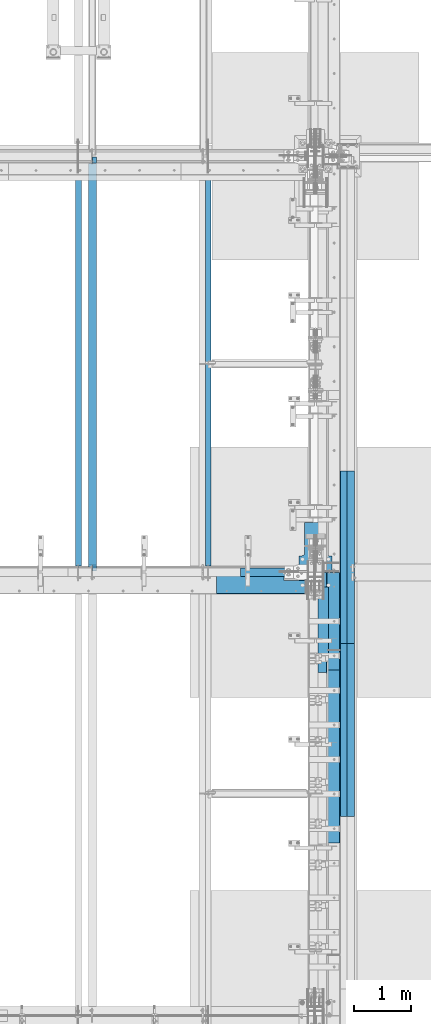
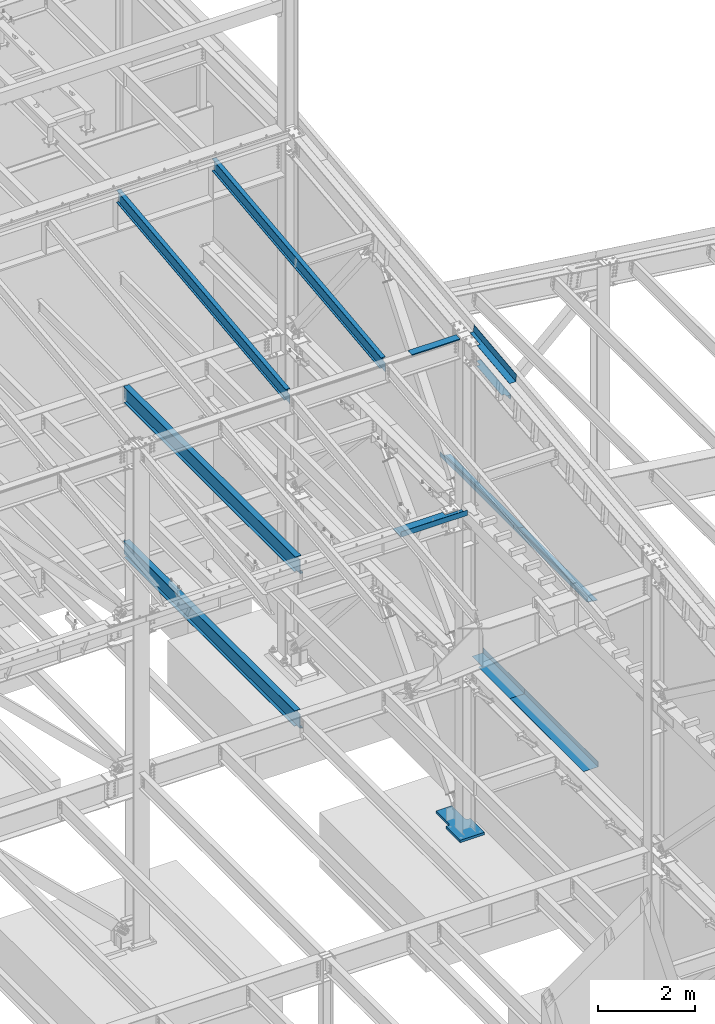
# One storey, part 740 of 1179: 15 beams, 13 elements without a shape of their own.
"""IFC2X3 building model written with IfcOpenShell, lengths in millimetres."""

import ifcopenshell
import ifcopenshell.guid

model = None  # the IFC model being written
_history = None  # IfcOwnerHistory: only IFC2X3 demands one
_inside = {}  # id of a spatial element -> (the spatial element, [elements in it])
_under = {}  # id of a project, library or spatial element -> (it, [spatial elements below it])
_declared = {}  # id of a project -> (the project, [libraries it declares])
_typed = {}  # id of a type object -> (the type object, [elements of that type])
_made_of = {}  # id of a material, layer set ... -> (it, [elements and type objects made of it])


def new_model(schema):
    """Start an empty IFC model of exactly this schema.

    Asked for "IFC4X3", IfcOpenShell would pick the latest addendum, in which some entities
    have other attributes; the version numbers below select the first issue.
    IFC2X3 requires an IfcOwnerHistory on every rooted entity: one is made here for all.
    """
    global model, _history
    if schema == "IFC4X3":
        model = ifcopenshell.file(schema_version=(4, 3, 0, 0))
    else:
        model = ifcopenshell.file(schema=schema)
    _inside.clear()
    _under.clear()
    _declared.clear()
    _typed.clear()
    _made_of.clear()
    _history = None
    if model.schema == "IFC2X3":
        org = make("IfcOrganization", Name="unknown")
        user = make(
            "IfcPersonAndOrganization",
            ThePerson=make("IfcPerson", FamilyName="unknown"),
            TheOrganization=org,
        )
        app = make(
            "IfcApplication",
            ApplicationDeveloper=org,
            Version="unknown",
            ApplicationFullName="unknown",
            ApplicationIdentifier="unknown",
        )
        _history = make(
            "IfcOwnerHistory",
            OwningUser=user,
            OwningApplication=app,
            ChangeAction="ADDED",
            CreationDate=0,
        )
    return model


def make(cls, **values):
    """One entity of the class cls with the attributes given. An attribute that is None is left unset."""
    return model.create_entity(
        cls, **{name: value for name, value in values.items() if value is not None}
    )


def rooted(cls, **values):
    """An entity with a GlobalId (a new one), such as an element, a storey or a relation."""
    return make(cls, GlobalId=ifcopenshell.guid.new(), OwnerHistory=_history, **values)


def si_unit(unit_type, name, prefix=None):
    """IfcSIUnit, for example si_unit("LENGTHUNIT", "METRE", prefix="MILLI")."""
    return make("IfcSIUnit", UnitType=unit_type, Prefix=prefix, Name=name)


def assignment(units):
    """IfcUnitAssignment: the units of a project."""
    return None if units is None else make("IfcUnitAssignment", Units=units)


def point(xyz):
    """IfcCartesianPoint."""
    return None if xyz is None else make("IfcCartesianPoint", Coordinates=xyz)


def direction(xyz):
    """IfcDirection."""
    return None if xyz is None else make("IfcDirection", DirectionRatios=xyz)


def frame(location, z_axis=None, x_axis=None):
    """IfcAxis2Placement3D, a coordinate frame: its origin and axes. An axis left out is left unset."""
    return make(
        "IfcAxis2Placement3D",
        Location=point(location),
        Axis=direction(z_axis),
        RefDirection=direction(x_axis),
    )


def origin_with_axes():
    """The frame at (0, 0, 0) with the z axis (0, 0, 1) and the x axis (1, 0, 0) written out."""
    return frame((0.0, 0.0, 0.0), z_axis=(0.0, 0.0, 1.0), x_axis=(1.0, 0.0, 0.0))


def place(relative_to, where):
    """IfcLocalPlacement: puts the frame where relative to a parent placement (None: the world)."""
    return make(
        "IfcLocalPlacement", PlacementRelTo=relative_to, RelativePlacement=where
    )


def context(
    kind, dimensions, precision=None, world=None, true_north=None, identifier=None
):
    """IfcGeometricRepresentationContext, for example the 3D "Model" context."""
    return make(
        "IfcGeometricRepresentationContext",
        ContextIdentifier=identifier,
        ContextType=kind,
        CoordinateSpaceDimension=dimensions,
        Precision=precision,
        WorldCoordinateSystem=world,
        TrueNorth=true_north,
    )


def subcontext(parent, identifier, kind, view, scale=None):
    """IfcGeometricRepresentationSubContext, for example "Body" below "Model"."""
    return make(
        "IfcGeometricRepresentationSubContext",
        ContextIdentifier=identifier,
        ContextType=kind,
        ParentContext=parent,
        TargetScale=scale,
        TargetView=view,
    )


def project(units=None, contexts=None):
    """IfcProject with its units and contexts."""
    return rooted(
        "IfcProject",
        Name="project",
        RepresentationContexts=contexts,
        UnitsInContext=assignment(units),
    )


def spatial(cls, under=None, at=None, **own):
    """A site, building, storey or space (cls), placed at a placement, below another one or the project."""
    s = rooted(cls, ObjectPlacement=at, **own)
    if under is not None:
        _under.setdefault(under.id(), (under, []))[1].append(s)
    return s


def faces_of(points, faces, orient=None, outer=None):
    """IfcFace entities. A face is a list of loops; a loop is a list of indices into points, from 0.

    orient and outer hold one flag for each loop. By default every Orientation is true, the
    first loop of a face is its IfcFaceOuterBound and the others are IfcFaceBound.
    """
    made = []
    for i, loops in enumerate(faces):
        bounds = []
        for j, loop in enumerate(loops):
            is_outer = j == 0 if outer is None else outer[i][j]
            bounds.append(
                make(
                    "IfcFaceOuterBound" if is_outer else "IfcFaceBound",
                    Bound=make("IfcPolyLoop", Polygon=[points[k] for k in loop]),
                    Orientation=True if orient is None else orient[i][j],
                )
            )
        made.append(make("IfcFace", Bounds=bounds))
    return made


def faceted_brep(points, faces, orient=None, outer=None, voids=None):
    """IfcFacetedBrep: a solid bounded by flat faces; with voids (closed shells), ...WithVoids."""
    shared = [point(p) for p in points]
    hull = make("IfcClosedShell", CfsFaces=faces_of(shared, faces, orient, outer))
    if voids is None:
        return make("IfcFacetedBrep", Outer=hull)
    return make(
        "IfcFacetedBrepWithVoids",
        Outer=hull,
        Voids=[
            make(cls, CfsFaces=faces_of(shared, fs, o, b)) for cls, fs, o, b in voids
        ],
    )


def shape(context_of_items, identifier, shape_type, items):
    """IfcShapeRepresentation: the items that make up one representation, for example the "Body"."""
    return make(
        "IfcShapeRepresentation",
        ContextOfItems=context_of_items,
        RepresentationIdentifier=identifier,
        RepresentationType=shape_type,
        Items=items,
    )


def material(Name=None, Category=None):
    """IfcMaterial."""
    return make("IfcMaterial", Name=Name, Category=Category)


def made_of(thing, what):
    """Note that an element or type object is made of a material, layer set ...; save() writes the relation."""
    if what is not None:
        _made_of.setdefault(what.id(), (what, []))[1].append(thing)
    return thing


def type_object(cls, material=None, **own):
    """A type object (cls), such as IfcWallType, which elements share."""
    return made_of(rooted(cls, **own), material)


def element(
    cls,
    number,
    at=None,
    inside=None,
    cuts=None,
    type_object=None,
    material=None,
    context=None,
    identifier="Body",
    shape_type=None,
    held_by="IfcProductDefinitionShape",
    body=None,
    shapes=None,
    **own,
):
    """One element of the class cls, such as IfcWall. Its Tag is "e" and its number.

    at: its placement. inside: the storey or other place that contains it. cuts: it is an
    opening in that element (IfcRelVoidsElement). A single representation is given by context,
    identifier, shape_type and body (its items); several are given by shapes. held_by: the class
    of the entity that holds the representations. save() writes the other relations.
    """
    e = rooted(cls, Tag="e%d" % number, ObjectPlacement=at, **own)
    if body is not None:
        shapes = [shape(context, identifier, shape_type, body)]
    if shapes is not None:
        e.Representation = make(held_by, Representations=shapes)
    if inside is not None:
        _inside.setdefault(inside.id(), (inside, []))[1].append(e)
    if cuts is not None:
        rooted(
            "IfcRelVoidsElement", RelatingBuildingElement=cuts, RelatedOpeningElement=e
        )
    if type_object is not None:
        _typed.setdefault(type_object.id(), (type_object, []))[1].append(e)
    return made_of(e, material)


def aggregate(whole, parts):
    """IfcRelAggregates: a whole, such as a stair, and the parts it consists of."""
    return rooted("IfcRelAggregates", RelatingObject=whole, RelatedObjects=parts)


def save(model, path):
    """Write the relations noted so far, then the file.

    IfcRelAggregates (storeys below a building ...), IfcRelContainedInSpatialStructure (elements
    in a storey), IfcRelDefinesByType, IfcRelAssociatesMaterial and IfcRelDeclares: one each for
    every whole, place, type object, material and project.
    """
    for whole, parts in _under.values():
        aggregate(whole, parts)
    for where, things in _inside.values():
        rooted(
            "IfcRelContainedInSpatialStructure",
            RelatedElements=things,
            RelatingStructure=where,
        )
    for kind, things in _typed.values():
        rooted("IfcRelDefinesByType", RelatedObjects=things, RelatingType=kind)
    for what, things in _made_of.values():
        rooted("IfcRelAssociatesMaterial", RelatedObjects=things, RelatingMaterial=what)
    for by, libraries in _declared.values():
        rooted("IfcRelDeclares", RelatingContext=by, RelatedDefinitions=libraries)
    model.write(path)


model = new_model("IFC2X3")

# Units and contexts
model_context = context("Model", 3, precision=1e-05, world=origin_with_axes())
body_context = subcontext(model_context, "Body", "Model", "MODEL_VIEW")
ifc_project = project(units=[si_unit("LENGTHUNIT", "METRE", prefix="MILLI"), si_unit("AREAUNIT", "SQUARE_METRE"), si_unit("VOLUMEUNIT", "CUBIC_METRE"), si_unit("MASSUNIT", "GRAM", prefix="KILO"), si_unit("TIMEUNIT", "SECOND"), si_unit("PLANEANGLEUNIT", "RADIAN"), si_unit("SOLIDANGLEUNIT", "STERADIAN"), si_unit("THERMODYNAMICTEMPERATUREUNIT", "DEGREE_CELSIUS"), si_unit("LUMINOUSINTENSITYUNIT", "LUMEN")], contexts=[model_context])

# Site, building, storey
site_placement = place(None, origin_with_axes())
site = spatial("IfcSite", under=ifc_project, at=site_placement, CompositionType="ELEMENT")
building_placement = place(site_placement, origin_with_axes())
building = spatial("IfcBuilding", under=site, at=building_placement, Name="Undefined", CompositionType="ELEMENT")
storey_placement = place(building_placement, origin_with_axes())
storey = spatial("IfcBuildingStorey", under=building, at=storey_placement, Name="Undefined", CompositionType="ELEMENT", Elevation=0.0)

# Assembly, beam
assembly_1_placement = place(storey_placement, origin_with_axes())
assembly_1 = element("IfcElementAssembly", 1, at=assembly_1_placement, inside=storey, Name="BEAM", AssemblyPlace="NOTDEFINED", PredefinedType="RIGID_FRAME")
ifc_material_1 = material(Name="STEEL/A36")
beam_type_1 = type_object("IfcBeamType", PredefinedType="NOTDEFINED")
beam_1_placement = place(assembly_1_placement, frame((23562.4690078236, 27124.0249999698, 12269.3906250184), z_axis=(-1.0, 0.0, 0.0), x_axis=(0.0, 0.0, 1.0)))
beam_1 = element("IfcBeam", 2, at=beam_1_placement, type_object=beam_type_1, material=ifc_material_1, Name="BENT_PLATE", context=body_context, shape_type="Brep", body=[
    faceted_brep([(-2.91038304567337e-11, -4.76250000000073, -575.469), (-2.91038304567337e-11, -4.76250000000073, 575.469), (2.91038304567337e-11, 4.76250000000073, 575.469), (2.91038304567337e-11, 4.76250000000073, -575.469), (43.0065173000457, 4.76249999974607, 575.469), (43.0065173000457, 4.76249999974607, -575.469), (32.3445868573126, -4.7625000001899, -575.469), (32.3445868573126, -4.7625000001899, 575.469), (25.4267481928364, -150.812499999749, 575.469), (25.4267481928364, -150.812499999749, -575.469), (16.9174425387409, -141.287499999748, -575.469), (16.9174425387409, -141.287499999748, 575.469), (2.84453562926501e-08, -150.812499999749, 575.469), (2.84453562926501e-08, -150.812499999749, -575.469), (2.84453562926501e-08, -141.287499999748, 575.469), (2.84453562926501e-08, -141.287499999748, -575.469)], [[[0, 1, 2, 3]], [[3, 2, 4, 5]], [[1, 0, 6, 7]], [[5, 4, 8, 9]], [[7, 6, 10, 11]], [[9, 8, 12, 13]], [[8, 4, 2, 1, 7, 11, 14, 12]], [[11, 10, 15, 14]], [[10, 6, 0, 3, 5, 9, 13, 15]], [[14, 15, 13, 12]]]),
])
aggregate(assembly_1, [beam_1])

assembly_2_placement = place(storey_placement, origin_with_axes())
assembly_2 = element("IfcElementAssembly", 3, at=assembly_2_placement, inside=storey, Name="BEAM", AssemblyPlace="NOTDEFINED", PredefinedType="RIGID_FRAME")
ifc_material_2 = material(Name="STEEL/A992")
beam_type_2 = type_object("IfcBeamType", Name="W16X31", PredefinedType="NOTDEFINED")
beam_2_placement = place(assembly_2_placement, frame((20370.8, 27051.0, 7812.0875), z_axis=(0.0, 0.0, 1.0), x_axis=(0.0, 1.0, 0.0)))
beam_2 = element("IfcBeam", 4, at=beam_2_placement, type_object=beam_type_2, material=ifc_material_2, Name="BEAM", ObjectType="W16X31", context=body_context, shape_type="Brep", body=[
    faceted_brep([(82.5499999999993, -3.17500000000291, 166.6875), (82.5499999999993, 3.17500000000291, 166.6875), (17.4624999999942, 3.17499999999927, 166.6875), (17.4624999999942, -3.17499999999927, 166.6875), (87.4100797087813, -3.17499999999927, 167.654229922588), (87.4100797087813, 3.17497144083973, 167.654229922588), (91.5302561769349, -3.17499999999927, 170.407243823066), (91.5302561769349, 3.17496966460385, 170.407243823066), (94.2832700774125, -3.17499999999927, 174.52742029122), (94.2832700774125, 3.1749670062818, 174.52742029122), (95.25, -3.17499999999927, 179.387499809265), (95.25, 3.1749638705769, 179.387499809265), (95.25, -69.8499999999985, 201.6125), (95.25, 69.8499999999985, 201.6125), (95.25, 69.8499999999985, 190.5), (95.25, 3.17499999999927, 190.5), (95.25, -3.17499999999927, 190.5), (95.25, -69.8499999999985, 190.5), (7196.1375, 3.17499999999927, -190.5), (7196.1375, 69.8500000000004, -190.5), (144.462499999994, 69.8499999999985, -190.5), (144.462499999994, 3.17549991607666, -190.5), (17.4624999999942, -3.17499999999927, -190.5), (17.4624999999942, -69.8499999999985, -190.5), (7323.1375, -69.8500000000004, -190.5), (7323.1375, -3.17499999999927, -190.5), (17.4624999999942, -69.8499999999985, -201.6125), (7323.1375, -69.8500000000004, -201.6125), (7196.1375, 69.8500000000004, -201.6125), (7196.1375, 3.17549991607484, -201.6125), (7323.1375, 3.17549991607484, -201.6125), (17.4624999999942, 3.17549991607666, -201.6125), (144.462499999994, 3.17549991607666, -201.6125), (144.462499999994, 69.8499999999985, -201.6125), (17.4624999999942, 3.17499999999927, -190.5), (7323.1375, 3.17499999999927, -190.5), (7323.1375, 3.17499999999927, 166.6875), (7323.1375, -3.17499999999927, 166.6875), (7235.82499980928, 3.17499999999927, 166.6875), (7235.82499980928, -3.17499999999927, 166.6875), (7230.96492029123, 3.17499999999927, 167.654229922588), (7230.96492029123, -3.17499999999927, 167.654229922588), (7226.84474382308, 3.17499999999927, 170.407243823066), (7226.84474382308, -3.17499999999927, 170.407243823066), (7224.0917299226, 3.17499999999927, 174.52742029122), (7224.0917299226, -3.17499999999927, 174.52742029122), (7223.12500000001, 3.17499999999927, 179.387499809265), (7223.12500000001, -3.17499999999927, 179.387499809265), (7223.12500000001, -69.8500000000004, 201.6125), (7223.12500000001, -69.8500000000004, 190.5), (7223.12500000001, -3.17499999999927, 190.5), (7223.12500000001, 3.17499999999927, 190.5), (7223.12500000001, 69.8500000000004, 190.5), (7223.12500000001, 69.8500000000004, 201.6125)], [[[0, 1, 2, 3]], [[4, 5, 1, 0]], [[6, 7, 5, 4]], [[8, 9, 7, 6]], [[10, 11, 9, 8]], [[12, 13, 14, 15, 11, 10, 16, 17]], [[18, 19, 20, 21]], [[22, 23, 24, 25]], [[23, 26, 27, 24]], [[28, 29, 30, 27, 26, 31, 32, 33]], [[21, 32, 31, 34]], [[20, 33, 32, 21]], [[19, 28, 33, 20]], [[18, 29, 28, 19]], [[35, 30, 29, 18]], [[25, 24, 27, 30, 35, 36, 37]], [[37, 36, 38, 39]], [[39, 38, 40, 41]], [[41, 40, 42, 43]], [[43, 42, 44, 45]], [[45, 44, 46, 47]], [[48, 49, 50, 47, 46, 51, 52, 53]], [[49, 48, 12, 17]], [[50, 49, 17, 16]], [[8, 6, 4, 0, 3, 22, 25, 37, 39, 41, 43, 45, 47, 50, 16, 10]], [[34, 31, 26, 23, 22, 3, 2]], [[51, 46, 44, 42, 40, 38, 36, 35, 18, 21, 34, 2, 1, 5, 7, 9, 11, 15]], [[52, 51, 15, 14]], [[53, 52, 14, 13]], [[48, 53, 13, 12]]]),
])
aggregate(assembly_2, [beam_2])

assembly_3_placement = place(storey_placement, origin_with_axes())
assembly_3 = element("IfcElementAssembly", 5, at=assembly_3_placement, inside=storey, Name="BEAM", AssemblyPlace="NOTDEFINED", PredefinedType="RIGID_FRAME")
beam_3_placement = place(assembly_3_placement, frame((20370.8, 27051.0, 3900.4875), z_axis=(0.0, 0.0, 1.0), x_axis=(0.0, 1.0, 0.0)))
beam_3 = element("IfcBeam", 6, at=beam_3_placement, type_object=beam_type_2, material=ifc_material_2, Name="BEAM", ObjectType="W16X31", context=body_context, shape_type="Brep", body=[
    faceted_brep([(114.300000190742, -3.17499999999927, 169.8625), (114.300000190742, 3.17497080806788, 169.8625), (19.0500000762049, 3.17499999999382, 169.8625), (19.0499999238054, -3.17500000000564, 169.8625), (119.160079708789, -3.17499999999927, 170.829229922588), (119.160079708789, 3.17497018437643, 170.829229922588), (123.280256176942, -3.17499999999927, 173.582243823066), (123.280256176942, 3.1749684082497, 173.582243823066), (126.03327007742, -3.17499999999927, 177.70242029122), (126.03327007742, 3.17496575008772, 177.70242029122), (127.000000000007, -3.17499999999927, 182.562499809265), (127.000000000007, 3.174962614572, 182.562499809265), (127.000000000007, -69.8499999999985, 201.6125), (127.000000000007, 69.8499999999985, 201.6125), (127.000000000007, 69.8499999999985, 190.5), (127.000000000007, 3.17499999999927, 190.5), (127.000000000007, -3.17499999999927, 190.5), (127.000000000007, -69.8499999999985, 190.5), (7195.34375, 3.17499999999927, -190.5), (7195.34375, 69.8499999999985, -190.5), (146.049999999996, 69.8499999999985, -190.5), (146.049999999996, 3.17549991607666, -190.5), (19.0499999999993, -3.17499999999927, -190.5), (19.0499999999993, -69.8499999999985, -190.5), (7322.34375, -69.8499999999985, -190.5), (7322.34375, -3.17499999999927, -190.5), (19.0499999999993, -69.8499999999985, -201.6125), (7322.34375, -69.8499999999985, -201.6125), (7195.34375, 69.8499999999985, -201.6125), (7195.34375, 3.17549991607666, -201.6125), (7322.34375, 3.17549991607666, -201.6125), (19.0499999999993, 3.17549991607666, -201.6125), (146.049999999996, 3.17549991607666, -201.6125), (146.049999999996, 69.8499999999985, -201.6125), (19.0499999999993, 3.17499999999927, -190.5), (7322.34375, 3.17499999999927, -190.5), (7322.34375, 3.17499999999927, 169.8625), (7322.34375, -3.17499999999927, 169.8625), (7227.09374980925, 3.17499999999927, 169.8625), (7227.09374980925, -3.17499999999927, 169.8625), (7222.2336702912, 3.17499999999927, 170.829229922588), (7222.2336702912, -3.17499999999927, 170.829229922588), (7218.11349382305, 3.17499999999927, 173.582243823066), (7218.11349382305, -3.17499999999927, 173.582243823066), (7215.36047992257, 3.17499999999927, 177.70242029122), (7215.36047992257, -3.17499999999927, 177.70242029122), (7214.39374999998, 3.17499999999927, 182.562499809265), (7214.39374999998, -3.17499999999927, 182.562499809265), (7214.39374999998, -69.8499999999985, 201.6125), (7214.39374999998, -69.8499999999985, 190.5), (7214.39374999998, -3.17499999999927, 190.5), (7214.39374999998, 3.17499999999927, 190.5), (7214.39374999998, 69.8499999999985, 190.5), (7214.39374999998, 69.8499999999985, 201.6125)], [[[0, 1, 2, 3]], [[4, 5, 1, 0]], [[6, 7, 5, 4]], [[8, 9, 7, 6]], [[10, 11, 9, 8]], [[12, 13, 14, 15, 11, 10, 16, 17]], [[18, 19, 20, 21]], [[22, 23, 24, 25]], [[23, 26, 27, 24]], [[28, 29, 30, 27, 26, 31, 32, 33]], [[21, 32, 31, 34]], [[20, 33, 32, 21]], [[19, 28, 33, 20]], [[18, 29, 28, 19]], [[35, 30, 29, 18]], [[25, 24, 27, 30, 35, 36, 37]], [[37, 36, 38, 39]], [[39, 38, 40, 41]], [[41, 40, 42, 43]], [[43, 42, 44, 45]], [[45, 44, 46, 47]], [[48, 49, 50, 47, 46, 51, 52, 53]], [[49, 48, 12, 17]], [[50, 49, 17, 16]], [[8, 6, 4, 0, 3, 22, 25, 37, 39, 41, 43, 45, 47, 50, 16, 10]], [[34, 31, 26, 23, 22, 3, 2]], [[51, 46, 44, 42, 40, 38, 36, 35, 18, 21, 34, 2, 1, 5, 7, 9, 11, 15]], [[52, 51, 15, 14]], [[53, 52, 14, 13]], [[48, 53, 13, 12]]]),
])
aggregate(assembly_3, [beam_3])

assembly_4_placement = place(storey_placement, origin_with_axes())
assembly_4 = element("IfcElementAssembly", 7, at=assembly_4_placement, inside=storey, Name="BEAM", AssemblyPlace="NOTDEFINED", PredefinedType="RIGID_FRAME")
beam_type_3 = type_object("IfcBeamType", PredefinedType="NOTDEFINED")
beam_4_placement = place(assembly_4_placement, frame((24350.6630000267, 26167.3979850945, 12206.9566078406), z_axis=(0.0, -0.993676146336441, -0.112284087038017), x_axis=(1.0, 0.0, 0.0)))
beam_4 = element("IfcBeam", 8, at=beam_4_placement, type_object=beam_type_3, material=ifc_material_1, Name="BENT_PLATE", context=body_context, shape_type="Brep", body=[
    faceted_brep([(71.4348426932302, -3.25796043364244, -469.707289102356), (71.4348773263773, 3.1749999998101, -469.707292572679), (71.4353513674432, 3.17499999964093, -885.031499999506), (71.4353167336194, -3.17500000035579, -885.031499999506), (3.63797880709171e-12, -3.17500000018845, -469.707274688342), (3.63797880709171e-12, 3.17499999980828, -469.707278158454), (153.986999996607, 3.17500000035761, 885.031499999499), (0.0, 3.17499999963911, 885.031499999503), (0.0, -3.17500000035761, 885.031499999495), (160.336999996605, -3.17499999963911, 885.031499999503), (160.336999996623, 187.324999996392, 885.031499999426), (153.986999996625, 187.324999996392, 885.031499999426), (153.986999996643, 3.17499999964093, -885.031499999506), (153.986999996625, 187.324999995672, -885.031499999579), (160.336999996623, 187.324999995672, -885.031499999579), (160.336999996642, -3.17500000035579, -885.031499999506)], [[[0, 1, 2, 3]], [[4, 5, 1, 0]], [[6, 7, 8, 9, 10, 11]], [[12, 6, 11, 13]], [[10, 14, 13, 11]], [[9, 15, 14, 10]], [[12, 13, 14, 15, 3, 2]], [[7, 6, 12, 2, 1, 5]], [[8, 7, 5, 4]], [[15, 9, 8, 4, 0, 3]]]),
])

assembly_5_placement = place(storey_placement, origin_with_axes())
assembly_5 = element("IfcElementAssembly", 9, at=assembly_5_placement, inside=storey, Name="BEAM", AssemblyPlace="NOTDEFINED", PredefinedType="RIGID_FRAME")
beam_type_4 = type_object("IfcBeamType", PredefinedType="NOTDEFINED")
beam_5_placement = place(assembly_5_placement, frame((23351.3315, 26673.175, 8147.05000610352), z_axis=(1.0, 0.0, 0.0), x_axis=(0.0, 0.0, -1.0)))
beam_5 = element("IfcBeam", 10, at=beam_5_placement, type_object=beam_type_4, material=ifc_material_1, Name="BENT_PLATE", context=body_context, shape_type="Brep", body=[
    faceted_brep([(133.350006103517, 346.074999237058, 399.256000924448), (127.000006103516, 346.074999237058, 399.256000924448), (127.000006103516, 234.950009844619, 399.256000935529), (133.350006103517, 234.950009844619, 399.256000935529), (133.350006103517, 234.950012207035, 792.956500011082), (127.000006103516, 234.950012207035, 792.9565), (0.0, -3.17499999999927, -792.9565), (0.0, -3.17499999999927, 792.9565), (0.0, 3.17499999999927, 792.9565), (0.0, 3.17499999999927, -792.9565), (127.000006103516, 3.17499999999927, 792.9565), (127.000006103516, 3.17499999999927, -792.9565), (133.350006103517, -3.17499999999927, -792.9565), (127.000006103516, 346.074999237058, -792.9565), (133.350006103517, 346.074999237058, -792.9565), (133.350006103517, -3.17499999999927, 792.9565)], [[[0, 1, 2, 3]], [[4, 3, 2, 5]], [[6, 7, 8, 9]], [[9, 8, 10, 11]], [[12, 6, 9, 11, 13, 14]], [[7, 6, 12, 15]], [[10, 8, 7, 15, 4, 5]], [[1, 13, 11, 10, 5, 2]], [[14, 13, 1, 0]], [[15, 12, 14, 0, 3, 4]]]),
])
aggregate(assembly_5, [beam_5])

# Beam
beam_type_5 = type_object("IfcBeamType", PredefinedType="NOTDEFINED")
beam_6_placement = place(assembly_4_placement, frame((24350.6629999506, 26169.0533384615, 11678.3376825604), z_axis=(0.0, -0.993676146336441, -0.112284087038017), x_axis=(1.0, 0.0, 0.0)))
beam_6 = element("IfcBeam", 11, at=beam_6_placement, type_object=beam_type_5, material=ifc_material_1, Name="BENT_PLATE", context=body_context, shape_type="Brep", body=[
    faceted_brep([(76.1995000488168, -3.17611935427885, -481.012500018212), (76.1995000488168, 3.17449425947234, -481.012500015731), (76.1995000488168, 3.17499999973916, -627.062499999662), (76.1995000488168, -3.17500000025575, -627.062499999654), (0.0, -3.17500000019209, -481.012500018212), (0.0, 3.17499999980464, -481.012500015735), (76.1995000491042, -3.0934924359135, 559.106213566753), (76.1995000491042, 3.25712117782132, 559.106213569263), (0.0, 3.17500000022665, 559.106213569263), (0.0, -3.17499999977008, 559.106213566753), (76.1995000491042, -3.09372775534393, 627.062500281074), (76.1995000491042, 3.17500000024665, 627.06249999964), (179.387000045364, -3.17499999975371, 627.062499999643), (179.387000045364, -136.524999944424, 627.062499999698), (185.737000045363, -136.524999944424, 627.062499999698), (185.737000045363, 3.17500000023938, 627.06249999964), (185.737000045363, 3.17499999973188, -627.062499999658), (185.737000045363, -136.524999944932, -627.062499999603), (179.387000045364, -136.524999944932, -627.062499999603), (179.387000045364, -3.17500000026303, -627.062499999658)], [[[0, 1, 2, 3]], [[4, 5, 1, 0]], [[6, 7, 8, 9]], [[10, 11, 7, 6]], [[12, 13, 14, 15, 11, 10]], [[16, 15, 14, 17]], [[13, 18, 17, 14]], [[12, 19, 18, 13]], [[16, 17, 18, 19, 3, 2]], [[8, 7, 11, 15, 16, 2, 1, 5]], [[9, 8, 5, 4]], [[19, 12, 10, 6, 9, 4, 0, 3]]]),
])

aggregate(assembly_4, [beam_4, beam_6])

# Assembly, beam
assembly_6_placement = place(storey_placement, origin_with_axes())
assembly_6 = element("IfcElementAssembly", 12, at=assembly_6_placement, inside=storey, Name="PLATE", AssemblyPlace="NOTDEFINED", PredefinedType="RIGID_FRAME")
beam_type_6 = type_object("IfcBeamType", PredefinedType="NOTDEFINED")
beam_7_placement = place(assembly_6_placement, frame((24880.9652345644, 25793.6999999996, 7964.0487255808), z_axis=(-0.99100656978554, 0.0, 0.133813222971043), x_axis=(0.0, 1.0, 0.0)))
beam_7 = element("IfcBeam", 13, at=beam_7_placement, type_object=beam_type_6, material=ifc_material_1, Name="PLATE", context=body_context, shape_type="Brep", body=[
    faceted_brep([(0.0, 4.76249999999709, -114.3), (0.0, 4.76249999999709, 114.3), (3048.0, 4.76249999996799, 114.300000000025), (3048.0, 4.76250000002983, -114.300000000025), (0.0, -4.76249999999709, 114.3), (3048.0, -4.76250000003711, 114.300000000014), (0.0, -4.76249999999709, -114.3), (3048.0, -4.76249999997344, -114.300000000036)], [[[0, 1, 2, 3]], [[1, 4, 5, 2]], [[4, 6, 7, 5]], [[6, 0, 3, 7]], [[5, 7, 3, 2]], [[6, 4, 1, 0]]]),
])
aggregate(assembly_6, [beam_7])

assembly_7_placement = place(storey_placement, origin_with_axes())
assembly_7 = element("IfcElementAssembly", 14, at=assembly_7_placement, inside=storey, Name="PLATE", AssemblyPlace="NOTDEFINED", PredefinedType="RIGID_FRAME")
beam_8_placement = place(assembly_7_placement, frame((24880.9652345644, 22745.6999999996, 7964.0487255808), z_axis=(-0.99100656978554, 0.0, 0.133813222971043), x_axis=(0.0, 1.0, 0.0)))
beam_8 = element("IfcBeam", 15, at=beam_8_placement, type_object=beam_type_6, material=ifc_material_1, Name="PLATE", context=body_context, shape_type="Brep", body=[
    faceted_brep([(0.0, 4.76249999999709, -114.3), (0.0, 4.76249999999709, 114.3), (3048.0, 4.76249999996799, 114.300000000025), (3048.0, 4.76250000002983, -114.300000000025), (0.0, -4.76249999999709, 114.3), (3048.0, -4.76250000003711, 114.300000000014), (0.0, -4.76249999999709, -114.3), (3048.0, -4.76249999997344, -114.300000000036)], [[[0, 1, 2, 3]], [[1, 4, 5, 2]], [[4, 6, 7, 5]], [[6, 0, 3, 7]], [[5, 7, 3, 2]], [[6, 4, 1, 0]]]),
])
aggregate(assembly_7, [beam_8])

# Assembly, beams
assembly_8_placement = place(storey_placement, origin_with_axes())
assembly_8 = element("IfcElementAssembly", 16, at=assembly_8_placement, inside=storey, Name="BEAM", AssemblyPlace="NOTDEFINED", PredefinedType="RIGID_FRAME")
beam_type_7 = type_object("IfcBeamType", PredefinedType="NOTDEFINED")
beam_9_placement = place(assembly_8_placement, frame((24387.175012207, 26187.4, 4105.275), z_axis=(0.0, -1.0, 0.0), x_axis=(1.0, 0.0, 0.0)))
beam_9 = element("IfcBeam", 17, at=beam_9_placement, type_object=beam_type_7, material=ifc_material_1, Name="BENT_PLATE", context=body_context, shape_type="Brep", body=[
    faceted_brep([(84.1374893188477, -3.17500000000018, -457.200006103518), (84.1374893188477, 3.17500000000018, -457.200006103518), (84.1374893188477, 3.17500000000018, -860.424999999999), (84.1374893188477, -3.17500000000018, -860.424999999999), (0.0, -3.17500000000018, -457.200006103518), (0.0, 3.17500000000018, -457.200006103518), (346.07498779297, 3.17500000000109, 860.424999999999), (0.0, 3.17500000000018, 860.424999999999), (0.0, -3.17500000000018, 860.424999999999), (352.424987792969, -3.17499999999927, 860.424999999999), (352.424987792969, 130.175006103515, 860.424999999999), (346.07498779297, 130.175006103515, 860.424999999999), (346.07498779297, 3.17500000000109, -860.424999999999), (346.07498779297, 130.175006103515, -860.424999999999), (352.424987792969, 130.175006103515, -860.424999999999), (352.424987792969, -3.17499999999927, -860.424999999999)], [[[0, 1, 2, 3]], [[4, 5, 1, 0]], [[6, 7, 8, 9, 10, 11]], [[12, 6, 11, 13]], [[10, 14, 13, 11]], [[9, 15, 14, 10]], [[12, 13, 14, 15, 3, 2]], [[7, 6, 12, 2, 1, 5]], [[8, 7, 5, 4]], [[15, 9, 8, 4, 0, 3]]]),
])
beam_10_placement = place(assembly_8_placement, frame((24387.175012207, 23802.975, 4105.275), z_axis=(0.0, -1.0, 0.0), x_axis=(1.0, 0.0, 0.0)))
beam_10 = element("IfcBeam", 18, at=beam_10_placement, type_object=beam_type_7, material=ifc_material_1, Name="BENT_PLATE", context=body_context, shape_type="Brep", body=[
    faceted_brep([(0.0, -3.17499999999927, -1524.0), (6.00266503170133e-10, -3.17499999922438, 1524.00000000052), (6.00266503170133e-10, 3.17500000077416, 1524.00000000052), (0.0, 3.17499999999927, -1524.0), (346.07498779297, 3.17500000000109, 1524.0), (346.07498779297, 3.17500000000109, -1524.0), (352.424987792969, -3.17499999999927, -1524.0), (352.424987792969, -3.17499999999927, 1524.0), (346.07498779297, 130.175006103515, 1524.0), (346.07498779297, 130.175006103515, -1524.0), (352.424987792969, 130.175006103515, 1524.0), (352.424987792969, 130.175006103515, -1524.0)], [[[0, 1, 2, 3]], [[3, 2, 4, 5]], [[1, 0, 6, 7]], [[5, 4, 8, 9]], [[4, 2, 1, 7, 10, 8]], [[7, 6, 11, 10]], [[6, 0, 3, 5, 9, 11]], [[10, 11, 9, 8]]]),
])
aggregate(assembly_8, [beam_9, beam_10])

# Assembly, beam
assembly_9_placement = place(storey_placement, origin_with_axes())
assembly_9 = element("IfcElementAssembly", 19, at=assembly_9_placement, inside=storey, Name="BENT_PLATE", AssemblyPlace="NOTDEFINED", PredefinedType="RIGID_FRAME")
beam_type_8 = type_object("IfcBeamType", PredefinedType="NOTDEFINED")
beam_11_placement = place(assembly_9_placement, frame((24744.362499997, 24269.6999999996, 8102.29217706219), z_axis=(0.0, 1.0, 0.0), x_axis=(0.0, 0.0, -1.0)))
beam_11 = element("IfcBeam", 20, at=beam_11_placement, type_object=beam_type_8, material=ifc_material_1, Name="BENT_PLATE", context=body_context, shape_type="Brep", body=[
    faceted_brep([(-2.91038304567337e-11, -4.76250000000073, -1524.0), (-2.91038304567337e-11, -4.76250000000073, 1524.0), (2.91038304567337e-11, 4.76250000000073, 1524.0), (2.91038304567337e-11, 4.76250000000073, -1524.0), (114.300008765535, 4.76250001759399, 1524.0000000001), (114.300003051474, 4.7625000005828, -1524.0), (105.977955544956, -4.76249999945867, -1524.0), (105.977955544956, -4.76249999945867, 1524.0), (131.343048095475, -121.088742065571, 1524.0), (131.343048095475, -121.088742065571, -1524.0), (121.904205090902, -122.366970423507, 1524.0), (121.904205090902, -122.366970423507, -1524.0)], [[[0, 1, 2, 3]], [[3, 2, 4, 5]], [[1, 0, 6, 7]], [[5, 4, 8, 9]], [[4, 2, 1, 7, 10, 8]], [[7, 6, 11, 10]], [[6, 0, 3, 5, 9, 11]], [[10, 11, 9, 8]]]),
])
aggregate(assembly_9, [beam_11])

assembly_10_placement = place(storey_placement, origin_with_axes())
assembly_10 = element("IfcElementAssembly", 21, at=assembly_10_placement, inside=storey, Name="BENT_PLATE", AssemblyPlace="NOTDEFINED", PredefinedType="RIGID_FRAME")
beam_12_placement = place(assembly_10_placement, frame((24744.3624999971, 27317.6999999996, 8102.292177062), z_axis=(0.0, 1.0, 0.0), x_axis=(0.0, 0.0, -1.0)))
beam_12 = element("IfcBeam", 22, at=beam_12_placement, type_object=beam_type_8, material=ifc_material_1, Name="BENT_PLATE", context=body_context, shape_type="Brep", body=[
    faceted_brep([(-2.91038304567337e-11, -4.76250000000073, -1524.0), (-2.91038304567337e-11, -4.76250000000073, 1524.0), (2.91038304567337e-11, 4.76250000000073, 1524.0), (2.91038304567337e-11, 4.76250000000073, -1524.0), (114.300008765535, 4.76250001759399, 1524.0000000001), (114.300003051474, 4.7625000005828, -1524.0), (105.977955544956, -4.76249999945867, -1524.0), (105.977955544956, -4.76249999945867, 1524.0), (131.343048095475, -121.088742065571, 1524.0), (131.343048095475, -121.088742065571, -1524.0), (121.904205090902, -122.366970423507, 1524.0), (121.904205090902, -122.366970423507, -1524.0)], [[[0, 1, 2, 3]], [[3, 2, 4, 5]], [[1, 0, 6, 7]], [[5, 4, 8, 9]], [[4, 2, 1, 7, 10, 8]], [[7, 6, 11, 10]], [[6, 0, 3, 5, 9, 11]], [[10, 11, 9, 8]]]),
])
aggregate(assembly_10, [beam_12])

assembly_11_placement = place(storey_placement, origin_with_axes())
assembly_11 = element("IfcElementAssembly", 23, at=assembly_11_placement, inside=storey, Name="BEAM", AssemblyPlace="NOTDEFINED", PredefinedType="RIGID_FRAME")
beam_type_9 = type_object("IfcBeamType", Name="W12X22", PredefinedType="NOTDEFINED")
beam_13_placement = place(assembly_11_placement, frame((22415.5, 27068.4779321143, 12149.0171463666), z_axis=(0.0, -0.112284087038017, 0.993676146336441), x_axis=(0.0, 0.993676146336441, 0.112284087038017)))
beam_13 = element("IfcBeam", 24, at=beam_13_placement, type_object=beam_type_9, material=ifc_material_2, Name="BEAM", ObjectType="W12X22", context=body_context, shape_type="Brep", body=[
    faceted_brep([(-15.5407998117698, -3.17499999999927, -144.462499999911), (-16.7964975778959, -3.17487472700668, -155.574999999904), (135.603493906594, -3.17489667232439, -155.574999999968), (135.603493906547, -3.17499999999927, -144.462499999972), (135.603487048622, -50.7999999999993, -144.462499999972), (135.603487048618, -50.7999999999993, -155.574999999964), (7139.32426989316, 3.17499999999927, -144.462500002814), (7139.32426989316, 50.7999999999993, -144.462500002814), (135.603501703274, 50.7999999999993, -144.462499999974), (135.603494845222, 3.17489668907729, -144.462500001895), (135.603494845269, 3.17510329651486, -155.574999999966), (-16.7964975778959, 3.17512524196718, -155.574999999904), (-15.5407998117698, 3.17499999999927, -144.462499999911), (135.603501703274, 50.7999999999993, -155.574999999966), (7138.06857212703, 50.7999999999993, -155.575000002807), (7142.71544233383, 3.17499999999927, -114.451772291532), (7168.54976507951, 3.17499999999927, 114.173235457372), (7171.97241181248, 3.17499999999927, 144.462499997011), (7171.97241181248, 50.7999999999993, 144.462499997011), (7173.22810957861, 50.7999999999993, 155.574999997003), (7173.22810957861, -50.7999999999993, 155.574999997003), (7171.97241181248, -50.7999999999993, 144.462499997011), (7171.97241181248, -3.17499999999927, 144.462499997011), (7139.32426989316, -3.17499999999927, -144.462500002814), (7139.32426989316, -50.7999999999993, -144.462500002814), (7138.06857212703, -50.7999999999993, -155.575000002807), (-14.7372101429282, -3.17499999999927, -137.351003558748), (10.2521606948103, -3.17499999999927, 83.7964659398294), (10.2521606948103, 3.17499999999927, 83.7964659398294), (-14.7371967980653, 3.17499999999927, -137.350885461223), (92.2801267643408, -3.17499999999927, 74.5274145334315), (92.2801267643408, 3.17499999999927, 74.5274145334315), (97.2180202374875, -3.17499999999927, 74.9423214058406), (97.2180202374875, 3.17499999999927, 74.9423214058406), (101.621260964999, -3.17499999999927, 77.215295396114), (101.621260964999, 3.17499999999927, 77.215295396114), (104.819495461597, -3.17499999999927, 81.0002968187928), (104.819495461597, 3.17499999999927, 81.0002968187928), (106.325821517235, -3.17499999999927, 85.7210935183975), (106.325821517235, 3.17499999999927, 85.7210935183975), (112.963522565431, 3.17499999999927, 144.462499999876), (112.963522565431, 50.7999999999993, 144.462499999876), (114.219220331557, 50.7999999999993, 155.57499999987), (114.219220331557, -50.7999999999993, 155.57499999987), (112.963522565431, -50.7999999999993, 144.462499999876), (112.963522565431, -3.17499999999927, 144.462499999876)], [[[0, 1, 2, 3]], [[4, 3, 2, 5]], [[6, 7, 8, 9]], [[9, 10, 11, 12]], [[8, 13, 10, 9]], [[7, 14, 13, 8]], [[6, 15, 16, 17, 18, 19, 20, 21, 22, 23, 24, 25, 14, 7]], [[25, 24, 4, 5]], [[1, 11, 10, 13, 14, 25, 5, 2]], [[26, 27, 28, 29, 12, 11, 1, 0]], [[30, 31, 28, 27]], [[32, 33, 31, 30]], [[34, 35, 33, 32]], [[36, 37, 35, 34]], [[38, 39, 37, 36]], [[17, 16, 15, 6, 9, 12, 29, 28, 31, 33, 35, 37, 39, 40]], [[18, 17, 40, 41]], [[19, 18, 41, 42]], [[20, 19, 42, 43]], [[21, 20, 43, 44]], [[22, 21, 44, 45]], [[43, 42, 41, 40, 39, 38, 45, 44]], [[36, 34, 32, 30, 27, 26, 0, 3, 23, 22, 45, 38]], [[24, 23, 3, 4]]]),
])
aggregate(assembly_11, [beam_13])

assembly_12_placement = place(storey_placement, origin_with_axes())
assembly_12 = element("IfcElementAssembly", 25, at=assembly_12_placement, inside=storey, Name="BEAM", AssemblyPlace="NOTDEFINED", PredefinedType="RIGID_FRAME")
beam_14_placement = place(assembly_12_placement, frame((20129.5, 27068.4779321143, 12149.0171463666), z_axis=(0.0, -0.112284087038017, 0.993676146336441), x_axis=(0.0, 0.993676146336441, 0.112284087038017)))
beam_14 = element("IfcBeam", 26, at=beam_14_placement, type_object=beam_type_9, material=ifc_material_2, Name="BEAM", ObjectType="W12X22", context=body_context, shape_type="Brep", body=[
    faceted_brep([(-15.5407998117698, -3.17499999999927, -144.462499999911), (-16.7964975778959, -3.17487472700668, -155.574999999904), (135.603493906594, -3.17489667232439, -155.574999999968), (135.603493906547, -3.17499999999927, -144.462499999972), (135.603487048622, -50.7999999999993, -144.462499999972), (135.603487048618, -50.7999999999993, -155.574999999964), (7139.32426989316, 3.17499999999927, -144.462500002814), (7139.32426989316, 50.7999999999993, -144.462500002814), (135.603501703274, 50.7999999999993, -144.462499999974), (135.603494845222, 3.17489668907729, -144.462500001895), (135.603494845269, 3.17510329651486, -155.574999999966), (-16.7964975778959, 3.17512524196718, -155.574999999904), (-15.5407998117698, 3.17499999999927, -144.462499999911), (135.603501703274, 50.7999999999993, -155.574999999966), (7138.06857212703, 50.7999999999993, -155.575000002807), (7142.71544233383, 3.17499999999927, -114.451772291532), (7168.54976507951, 3.17499999999927, 114.173235457372), (7171.97241181248, 3.17499999999927, 144.462499997011), (7171.97241181248, 50.7999999999993, 144.462499997011), (7173.22810957861, 50.7999999999993, 155.574999997003), (7173.22810957861, -50.7999999999993, 155.574999997003), (7171.97241181248, -50.7999999999993, 144.462499997011), (7171.97241181248, -3.17499999999927, 144.462499997011), (7139.32426989316, -3.17499999999927, -144.462500002814), (7139.32426989316, -50.7999999999993, -144.462500002814), (7138.06857212703, -50.7999999999993, -155.575000002807), (-14.7372101429282, -3.17499999999927, -137.351003558748), (10.2521606948103, -3.17499999999927, 83.7964659398294), (10.2521606948103, 3.17499999999927, 83.7964659398294), (-14.7371967980653, 3.17499999999927, -137.350885461223), (92.2801267643408, -3.17499999999927, 74.5274145334315), (92.2801267643408, 3.17499999999927, 74.5274145334315), (97.2180202374875, -3.17499999999927, 74.9423214058406), (97.2180202374875, 3.17499999999927, 74.9423214058406), (101.621260964999, -3.17499999999927, 77.215295396114), (101.621260964999, 3.17499999999927, 77.215295396114), (104.819495461597, -3.17499999999927, 81.0002968187928), (104.819495461597, 3.17499999999927, 81.0002968187928), (106.325821517235, -3.17499999999927, 85.7210935183975), (106.325821517235, 3.17499999999927, 85.7210935183975), (112.963522565431, 3.17499999999927, 144.462499999876), (112.963522565431, 50.7999999999993, 144.462499999876), (114.219220331557, 50.7999999999993, 155.57499999987), (114.219220331557, -50.7999999999993, 155.57499999987), (112.963522565431, -50.7999999999993, 144.462499999876), (112.963522565431, -3.17499999999927, 144.462499999876)], [[[0, 1, 2, 3]], [[4, 3, 2, 5]], [[6, 7, 8, 9]], [[9, 10, 11, 12]], [[8, 13, 10, 9]], [[7, 14, 13, 8]], [[6, 15, 16, 17, 18, 19, 20, 21, 22, 23, 24, 25, 14, 7]], [[25, 24, 4, 5]], [[1, 11, 10, 13, 14, 25, 5, 2]], [[26, 27, 28, 29, 12, 11, 1, 0]], [[30, 31, 28, 27]], [[32, 33, 31, 30]], [[34, 35, 33, 32]], [[36, 37, 35, 34]], [[38, 39, 37, 36]], [[17, 16, 15, 6, 9, 12, 29, 28, 31, 33, 35, 37, 39, 40]], [[18, 17, 40, 41]], [[19, 18, 41, 42]], [[20, 19, 42, 43]], [[21, 20, 43, 44]], [[22, 21, 44, 45]], [[43, 42, 41, 40, 39, 38, 45, 44]], [[36, 34, 32, 30, 27, 26, 0, 3, 23, 22, 45, 38]], [[24, 23, 3, 4]]]),
])
aggregate(assembly_12, [beam_14])

assembly_13_placement = place(storey_placement, origin_with_axes())
assembly_13 = element("IfcElementAssembly", 27, at=assembly_13_placement, inside=storey, Name="COLUMN", AssemblyPlace="NOTDEFINED", PredefinedType="RIGID_FRAME")
ifc_material_3 = material(Name="STEEL/A572-GR.50")
beam_type_10 = type_object("IfcBeamType", PredefinedType="NOTDEFINED")
beam_15_placement = place(assembly_13_placement, frame((24307.8, 26758.90050354, -247.649999999999), z_axis=(-1.0, 0.0, 0.0), x_axis=(0.0, 1.0, 0.0)))
beam_15 = element("IfcBeam", 28, at=beam_15_placement, type_object=beam_type_10, material=ifc_material_3, context=body_context, shape_type="Brep", body=[
    faceted_brep([(584.199496459958, -31.75, 292.1), (584.199496459958, -31.75, 241.30000076336), (584.199496459958, 31.75, 241.30000076336), (584.199496459958, 31.75, 292.1), (588.066416150308, -31.75, 221.859682691178), (588.066416150308, 31.75, 221.859682691178), (599.078471752222, -31.75, 205.378976818563), (599.078471752222, 31.75, 205.378976818563), (615.559177624837, -31.75, 194.366921216651), (615.559177624837, 31.75, 194.366921216651), (634.999495697019, -31.75, 190.500001526299), (634.999495697019, 31.75, 190.500001526299), (1168.39847106933, -31.75, 190.500001526299), (1168.39848937988, 31.75, 190.500001526299), (0.0, -31.75, -292.1), (0.0, -31.75, 292.1), (0.0, 31.75, 292.1), (0.0, 31.75, -292.1), (584.199496459958, 31.75, -292.1), (584.199496459958, -31.75, -292.1), (584.199496459958, 31.75, -241.30000076336), (584.199496459958, -31.75, -241.30000076336), (588.066416150308, 31.75, -221.859682691178), (588.066416150308, -31.75, -221.859682691178), (599.078471752222, 31.75, -205.378976818563), (599.078471752222, -31.75, -205.378976818563), (615.559177624837, 31.75, -194.366921216651), (615.559177624837, -31.75, -194.366921216651), (634.999495697019, 31.75, -190.500001526299), (634.999495697019, -31.75, -190.500001526299), (1168.39847106933, -31.75, -190.500001526299), (1168.39848937988, 31.75, -190.500001526299)], [[[0, 1, 2, 3]], [[4, 5, 2, 1]], [[6, 7, 5, 4]], [[8, 9, 7, 6]], [[10, 11, 9, 8]], [[12, 13, 11, 10]], [[14, 15, 16, 17]], [[14, 17, 18, 19]], [[19, 18, 20, 21]], [[21, 20, 22, 23]], [[23, 22, 24, 25]], [[25, 24, 26, 27]], [[27, 26, 28, 29]], [[30, 29, 28, 31]], [[8, 6, 4, 1, 0, 15, 14, 19, 21, 23, 25, 27, 29, 30, 12, 10]], [[16, 15, 0, 3]], [[31, 28, 26, 24, 22, 20, 18, 17, 16, 3, 2, 5, 7, 9, 11, 13]], [[30, 31, 13, 12]]]),
])
aggregate(assembly_13, [beam_15])

save(model, "model.ifc")
